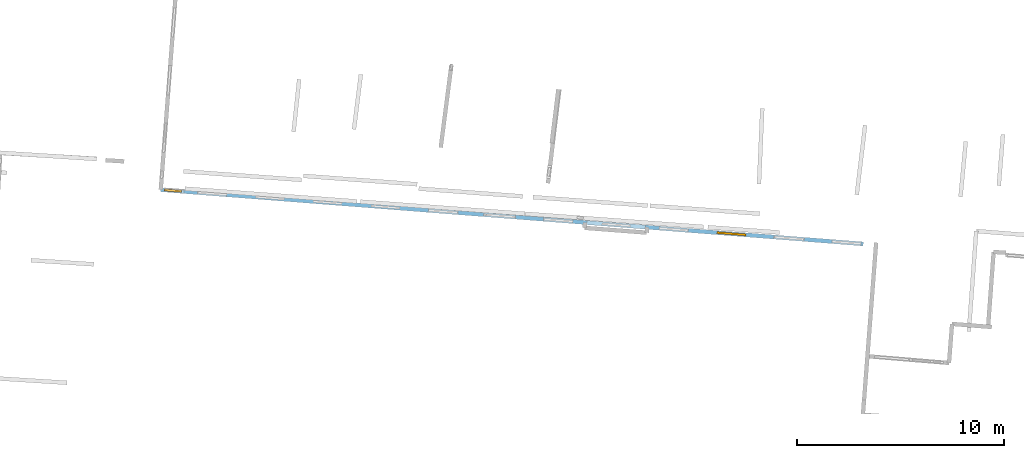
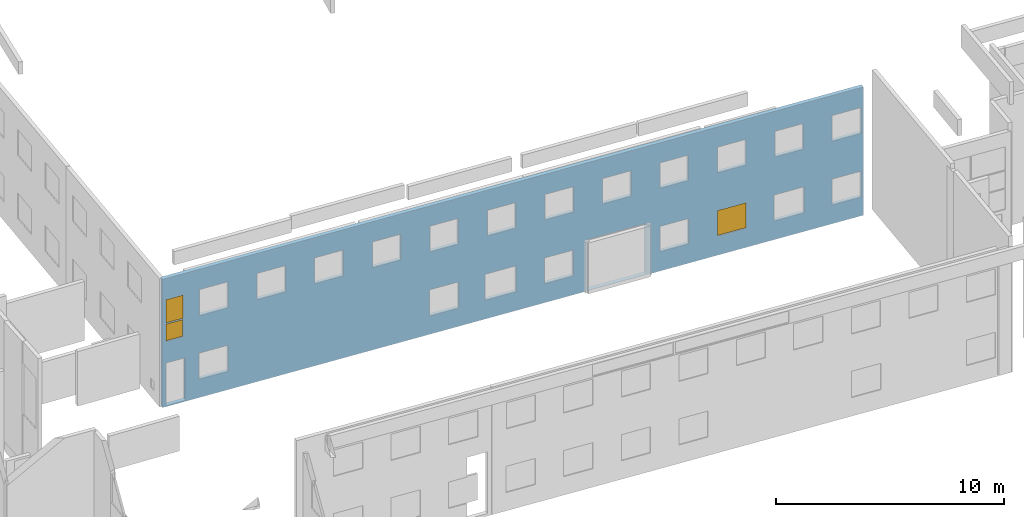
# One storey, part 13 of 27: 3 windows, 24 openings, plus 1 element that does not belong to this part.
"""IFC2X3 building model written with IfcOpenShell, lengths in metres."""

from ifc_helpers import new_model, entity, si_unit, converted_unit, derived_unit, direction, frame, frame_2d, origin, origin_2d_with_axis, place, context, subcontext, project, spatial, polyline, rectangle, outline, extrude, source, transform, mapped, material, layer, layer_set, layer_usage, type_object, type_shapes, element, fill, save


model = new_model("IFC2X3")

# Units and contexts
model_context = context("Model", 3, precision=1e-05, world=origin(), true_north=direction((0.0, 1.0)))
body_context = subcontext(model_context, "Body", "Model", "MODEL_VIEW")
ifc_project = project(units=[si_unit("LENGTHUNIT", "METRE"), si_unit("AREAUNIT", "SQUARE_METRE"), si_unit("VOLUMEUNIT", "CUBIC_METRE"), converted_unit("PLANEANGLEUNIT", "DEGREE", entity("IfcRatioMeasure", 0.0174532925199433), si_unit("PLANEANGLEUNIT", "RADIAN"), dimensions=[0, 0, 0, 0, 0, 0, 0]), si_unit("MASSUNIT", "GRAM", prefix="KILO"), derived_unit("MASSDENSITYUNIT", [(si_unit("MASSUNIT", "GRAM", prefix="KILO"), 1), (si_unit("LENGTHUNIT", "METRE"), -3)]), derived_unit("MOMENTOFINERTIAUNIT", [(si_unit("LENGTHUNIT", "METRE"), 4)]), si_unit("TIMEUNIT", "SECOND"), si_unit("FREQUENCYUNIT", "HERTZ"), si_unit("THERMODYNAMICTEMPERATUREUNIT", "DEGREE_CELSIUS"), derived_unit("THERMALTRANSMITTANCEUNIT", [(si_unit("MASSUNIT", "GRAM", prefix="KILO"), 1), (si_unit("THERMODYNAMICTEMPERATUREUNIT", "KELVIN"), -1), (si_unit("TIMEUNIT", "SECOND"), -3)]), derived_unit("VOLUMETRICFLOWRATEUNIT", [(si_unit("LENGTHUNIT", "METRE"), 3), (si_unit("TIMEUNIT", "SECOND"), -1)]), si_unit("ELECTRICCURRENTUNIT", "AMPERE"), si_unit("ELECTRICVOLTAGEUNIT", "VOLT"), si_unit("POWERUNIT", "WATT"), si_unit("FORCEUNIT", "NEWTON", prefix="KILO"), si_unit("ILLUMINANCEUNIT", "LUX"), si_unit("LUMINOUSFLUXUNIT", "LUMEN"), si_unit("LUMINOUSINTENSITYUNIT", "CANDELA"), derived_unit("USERDEFINED", [(si_unit("MASSUNIT", "GRAM", prefix="KILO"), -1), (si_unit("LENGTHUNIT", "METRE"), -2), (si_unit("TIMEUNIT", "SECOND"), 3), (si_unit("LUMINOUSFLUXUNIT", "LUMEN"), 1)]), derived_unit("LINEARVELOCITYUNIT", [(si_unit("LENGTHUNIT", "METRE"), 1), (si_unit("TIMEUNIT", "SECOND"), -1)]), si_unit("PRESSUREUNIT", "PASCAL"), derived_unit("USERDEFINED", [(si_unit("LENGTHUNIT", "METRE"), -2), (si_unit("MASSUNIT", "GRAM", prefix="KILO"), 1), (si_unit("TIMEUNIT", "SECOND"), -2)]), derived_unit("LINEARFORCEUNIT", [(si_unit("MASSUNIT", "GRAM", prefix="KILO"), 1), (si_unit("LENGTHUNIT", "METRE"), 1), (si_unit("TIMEUNIT", "SECOND"), -2), (si_unit("LENGTHUNIT", "METRE"), -1)]), derived_unit("PLANARFORCEUNIT", [(si_unit("MASSUNIT", "GRAM", prefix="KILO"), 1), (si_unit("LENGTHUNIT", "METRE"), 1), (si_unit("TIMEUNIT", "SECOND"), -2), (si_unit("LENGTHUNIT", "METRE"), -2)])], contexts=[model_context])

# Site, building, storey
placement_1 = place(None, origin())
site = spatial("IfcSite", under=ifc_project, at=placement_1, CompositionType="ELEMENT")
building = spatial("IfcBuilding", under=site, at=placement_1, CompositionType="ELEMENT")
storey_placement = place(placement_1, frame((0.0, 0.0, -61.043098449707)))
storey = spatial("IfcBuildingStorey", under=building, at=storey_placement, Name="level_-61.043098", CompositionType="ELEMENT", Elevation=-61.043098449707)

# Wall, openings, windows
ifc_material_1 = material(Name="Default wall")
ifc_layer = layer(ifc_material_1, 0.2)
ifc_layer_set = layer_set([ifc_layer], Name="wall_thickness_0.2000")
ifc_layer_usage = layer_usage(ifc_layer_set, "AXIS2", "POSITIVE", -0.1)
wall_type = type_object("IfcWallType", Name="wall_thickness_0.2000", PredefinedType="STANDARD", material=ifc_layer_set)
placement_2 = place(placement_1, frame((0.0, 0.0, -61.0783157348633)))
wall_placement = place(placement_2, frame((-70.5410936106186, 0.364161913204613, 0.0), z_axis=(0.0, 0.0, 1.0), x_axis=(0.997031285356377, -0.0769975065869715, 0.0)))
wall = element("IfcWallStandardCase", 1, at=wall_placement, inside=storey, type_object=wall_type, material=ifc_layer_usage, Name="Wall:863", ObjectType="Wall", context=body_context, shape_type="SweptSolid", body=[
    extrude(outline(polyline([(34.091740570846, -0.1), (34.091740570846, 0.1), (0.0, 0.1), (0.0, -0.1), (34.091740570846, -0.1)])), origin(), (0.0, 0.0, 1.0), 6.869140625),
])
opening_1_placement = place(wall_placement, frame((0.175669529657693, -0.1, 0.0593376159667969)))
element("IfcOpeningElement", 2, at=opening_1_placement, cuts=wall, Name="Opening : 950 x 2285 : 80", ObjectType="Opening", context=body_context, shape_type="SweptSolid", body=[
    extrude(rectangle(XDim=0.95, YDim=2.285, at=frame_2d((1.1425, 0.475), x_axis=(0.0, 1.0))), frame((0.0, 0.0, 0.0), z_axis=(0.0, 1.0, 0.0), x_axis=(0.0, 0.0, 1.0)), (0.0, 0.0, 1.0), 0.2),
])
opening_2_placement = place(wall_placement, frame((20.6733996380134, -0.1, 0.0425682067871094)))
element("IfcOpeningElement", 3, at=opening_2_placement, cuts=wall, Name="Opening : 2840 x 2715 : 81", ObjectType="Opening", context=body_context, shape_type="SweptSolid", body=[
    extrude(rectangle(XDim=2.84, YDim=2.715, at=frame_2d((1.3575, 1.42), x_axis=(0.0, 1.0))), frame((0.0, 0.0, 0.0), z_axis=(0.0, 1.0, 0.0), x_axis=(0.0, 0.0, 1.0)), (0.0, 0.0, 1.0), 0.2),
])
opening_3_placement = place(wall_placement, frame((21.4018079516808, -0.1, 4.43256759643555)))
element("IfcOpeningElement", 4, at=opening_3_placement, cuts=wall, Name="Opening : 1400 x 1370 : 82", ObjectType="Opening", context=body_context, shape_type="SweptSolid", body=[
    extrude(rectangle(XDim=1.4, YDim=1.37, at=frame_2d((0.685, 0.7), x_axis=(0.0, 1.0))), frame((0.0, 0.0, 0.0), z_axis=(0.0, 1.0, 0.0), x_axis=(0.0, 0.0, 1.0)), (0.0, 0.0, 1.0), 0.2),
])
opening_4_placement = place(wall_placement, frame((18.6005650597193, -0.1, 4.42756652832031)))
element("IfcOpeningElement", 5, at=opening_4_placement, cuts=wall, Name="Opening : 1405 x 1370 : 83", ObjectType="Opening", context=body_context, shape_type="SweptSolid", body=[
    extrude(rectangle(XDim=1.405, YDim=1.37, at=frame_2d((0.685, 0.7025), x_axis=(0.0, 1.0))), frame((0.0, 0.0, 0.0), z_axis=(0.0, 1.0, 0.0), x_axis=(0.0, 0.0, 1.0)), (0.0, 0.0, 1.0), 0.2),
])
opening_5_placement = place(wall_placement, frame((4.59927100477917, -0.1, 4.38933563232422)))
element("IfcOpeningElement", 6, at=opening_5_placement, cuts=wall, Name="Opening : 1410 x 1415 : 84", ObjectType="Opening", context=body_context, shape_type="SweptSolid", body=[
    extrude(rectangle(XDim=1.41, YDim=1.415, at=frame_2d((0.7075, 0.705), x_axis=(0.0, 1.0))), frame((0.0, 0.0, 0.0), z_axis=(0.0, 1.0, 0.0), x_axis=(0.0, 0.0, 1.0)), (0.0, 0.0, 1.0), 0.2),
])
opening_6_placement = place(wall_placement, frame((1.79896544522815, -0.1, 4.37933731079102)))
element("IfcOpeningElement", 7, at=opening_6_placement, cuts=wall, Name="Opening : 1405 x 1405 : 85", ObjectType="Opening", context=body_context, shape_type="SweptSolid", body=[
    extrude(rectangle(XDim=1.405, YDim=1.405, at=frame_2d((0.7025, 0.7025), x_axis=(0.0, 1.0))), frame((0.0, 0.0, 0.0), z_axis=(0.0, 1.0, 0.0), x_axis=(0.0, 0.0, 1.0)), (0.0, 0.0, 1.0), 0.2),
])
opening_7_placement = place(wall_placement, frame((7.40003180112796, -0.1, 4.39433670043945)))
element("IfcOpeningElement", 8, at=opening_7_placement, cuts=wall, Name="Opening : 1405 x 1395 : 86", ObjectType="Opening", context=body_context, shape_type="SweptSolid", body=[
    extrude(rectangle(XDim=1.405, YDim=1.395, at=frame_2d((0.6975, 0.7025), x_axis=(0.0, 1.0))), frame((0.0, 0.0, 0.0), z_axis=(0.0, 1.0, 0.0), x_axis=(0.0, 0.0, 1.0)), (0.0, 0.0, 1.0), 0.2),
])
opening_8_placement = place(wall_placement, frame((1.78067692275089, -0.1, 0.979335784912109)))
element("IfcOpeningElement", 9, at=opening_8_placement, cuts=wall, Name="Opening : 1420 x 1405 : 87", ObjectType="Opening", context=body_context, shape_type="SweptSolid", body=[
    extrude(rectangle(XDim=1.42, YDim=1.405, at=frame_2d((0.7025, 0.71), x_axis=(0.0, 1.0))), frame((0.0, 0.0, 0.0), z_axis=(0.0, 1.0, 0.0), x_axis=(0.0, 0.0, 1.0)), (0.0, 0.0, 1.0), 0.2),
])
opening_9_placement = place(wall_placement, frame((24.1869546370559, -0.1, 4.42756652832031)))
element("IfcOpeningElement", 10, at=opening_9_placement, cuts=wall, Name="Opening : 1400 x 1370 : 88", ObjectType="Opening", context=body_context, shape_type="SweptSolid", body=[
    extrude(rectangle(XDim=1.4, YDim=1.37, at=frame_2d((0.685, 0.7), x_axis=(0.0, 1.0))), frame((0.0, 0.0, 0.0), z_axis=(0.0, 1.0, 0.0), x_axis=(0.0, 0.0, 1.0)), (0.0, 0.0, 1.0), 0.2),
])
opening_10_placement = place(wall_placement, frame((29.7875311747154, -0.1, 4.41256713867188)))
element("IfcOpeningElement", 11, at=opening_10_placement, cuts=wall, Name="Opening : 1400 x 1385 : 89", ObjectType="Opening", context=body_context, shape_type="SweptSolid", body=[
    extrude(rectangle(XDim=1.4, YDim=1.385, at=frame_2d((0.6925, 0.7), x_axis=(0.0, 1.0))), frame((0.0, 0.0, 0.0), z_axis=(0.0, 1.0, 0.0), x_axis=(0.0, 0.0, 1.0)), (0.0, 0.0, 1.0), 0.2),
])
opening_11_placement = place(wall_placement, frame((32.5684003285411, -0.1, 4.41256713867188)))
element("IfcOpeningElement", 12, at=opening_11_placement, cuts=wall, Name="Opening : 1420 x 1390 : 90", ObjectType="Opening", context=body_context, shape_type="SweptSolid", body=[
    extrude(rectangle(XDim=1.42, YDim=1.39, at=frame_2d((0.695, 0.71), x_axis=(0.0, 1.0))), frame((0.0, 0.0, 0.0), z_axis=(0.0, 1.0, 0.0), x_axis=(0.0, 0.0, 1.0)), (0.0, 0.0, 1.0), 0.2),
])
opening_12_placement = place(wall_placement, frame((10.2015042481688, -0.1, 4.40756607055664)))
element("IfcOpeningElement", 13, at=opening_12_placement, cuts=wall, Name="Opening : 1405 x 1385 : 91", ObjectType="Opening", context=body_context, shape_type="SweptSolid", body=[
    extrude(rectangle(XDim=1.405, YDim=1.385, at=frame_2d((0.6925, 0.7025), x_axis=(0.0, 1.0))), frame((0.0, 0.0, 0.0), z_axis=(0.0, 1.0, 0.0), x_axis=(0.0, 0.0, 1.0)), (0.0, 0.0, 1.0), 0.2),
])
opening_13_placement = place(wall_placement, frame((12.9975627777284, -0.1, 4.40756607055664)))
element("IfcOpeningElement", 14, at=opening_13_placement, cuts=wall, Name="Opening : 1405 x 1385 : 92", ObjectType="Opening", context=body_context, shape_type="SweptSolid", body=[
    extrude(rectangle(XDim=1.405, YDim=1.385, at=frame_2d((0.6925, 0.7025), x_axis=(0.0, 1.0))), frame((0.0, 0.0, 0.0), z_axis=(0.0, 1.0, 0.0), x_axis=(0.0, 0.0, 1.0)), (0.0, 0.0, 1.0), 0.2),
])
opening_14_placement = place(wall_placement, frame((15.7978721303258, -0.1, 4.41756820678711)))
element("IfcOpeningElement", 15, at=opening_14_placement, cuts=wall, Name="Opening : 1405 x 1375 : 93", ObjectType="Opening", context=body_context, shape_type="SweptSolid", body=[
    extrude(rectangle(XDim=1.405, YDim=1.375, at=frame_2d((0.6875, 0.7025), x_axis=(0.0, 1.0))), frame((0.0, 0.0, 0.0), z_axis=(0.0, 1.0, 0.0), x_axis=(0.0, 0.0, 1.0)), (0.0, 0.0, 1.0), 0.2),
])
opening_15_placement = place(wall_placement, frame((26.9919317277781, -0.1, 4.41256713867188)))
element("IfcOpeningElement", 16, at=opening_15_placement, cuts=wall, Name="Opening : 1400 x 1380 : 94", ObjectType="Opening", context=body_context, shape_type="SweptSolid", body=[
    extrude(rectangle(XDim=1.4, YDim=1.38, at=frame_2d((0.69, 0.7), x_axis=(0.0, 1.0))), frame((0.0, 0.0, 0.0), z_axis=(0.0, 1.0, 0.0), x_axis=(0.0, 0.0, 1.0)), (0.0, 0.0, 1.0), 0.2),
])
opening_16_placement = place(wall_placement, frame((15.6733990489944, -0.1, 1.00256729125977)))
element("IfcOpeningElement", 17, at=opening_16_placement, cuts=wall, Name="Opening : 1535 x 1400 : 95", ObjectType="Opening", context=body_context, shape_type="SweptSolid", body=[
    extrude(rectangle(XDim=1.535, YDim=1.4, at=frame_2d((0.7, 0.7675), x_axis=(0.0, 1.0))), frame((0.0, 0.0, 0.0), z_axis=(0.0, 1.0, 0.0), x_axis=(0.0, 0.0, 1.0)), (0.0, 0.0, 1.0), 0.2),
])
opening_17_placement = place(wall_placement, frame((18.5683994261943, -0.1, 1.01256561279297)))
element("IfcOpeningElement", 18, at=opening_17_placement, cuts=wall, Name="Opening : 1425 x 1390 : 96", ObjectType="Opening", context=body_context, shape_type="SweptSolid", body=[
    extrude(rectangle(XDim=1.425, YDim=1.39, at=frame_2d((0.695, 0.7125), x_axis=(0.0, 1.0))), frame((0.0, 0.0, 0.0), z_axis=(0.0, 1.0, 0.0), x_axis=(0.0, 0.0, 1.0)), (0.0, 0.0, 1.0), 0.2),
])
opening_18_placement = place(wall_placement, frame((24.1934015219894, -0.1, 1.03256607055664)))
element("IfcOpeningElement", 19, at=opening_18_placement, cuts=wall, Name="Opening : 1405 x 1365 : 97", ObjectType="Opening", context=body_context, shape_type="SweptSolid", body=[
    extrude(rectangle(XDim=1.405, YDim=1.365, at=frame_2d((0.6825, 0.7025), x_axis=(0.0, 1.0))), frame((0.0, 0.0, 0.0), z_axis=(0.0, 1.0, 0.0), x_axis=(0.0, 0.0, 1.0)), (0.0, 0.0, 1.0), 0.2),
])
opening_19_placement = place(wall_placement, frame((29.7484020893475, -0.1, 0.992565155029297)))
element("IfcOpeningElement", 20, at=opening_19_placement, cuts=wall, Name="Opening : 1480 x 1405 : 98", ObjectType="Opening", context=body_context, shape_type="SweptSolid", body=[
    extrude(rectangle(XDim=1.48, YDim=1.405, at=frame_2d((0.7025, 0.74), x_axis=(0.0, 1.0))), frame((0.0, 0.0, 0.0), z_axis=(0.0, 1.0, 0.0), x_axis=(0.0, 0.0, 1.0)), (0.0, 0.0, 1.0), 0.2),
])
opening_20_placement = place(wall_placement, frame((32.5734009472892, -0.1, 1.00256729125977)))
element("IfcOpeningElement", 21, at=opening_20_placement, cuts=wall, Name="Opening : 1415 x 1395 : 99", ObjectType="Opening", context=body_context, shape_type="SweptSolid", body=[
    extrude(rectangle(XDim=1.415, YDim=1.395, at=frame_2d((0.6975, 0.7075), x_axis=(0.0, 1.0))), frame((0.0, 0.0, 0.0), z_axis=(0.0, 1.0, 0.0), x_axis=(0.0, 0.0, 1.0)), (0.0, 0.0, 1.0), 0.2),
])
opening_21_placement = place(wall_placement, frame((12.9833987386074, -0.1, 0.972564697265625)))
element("IfcOpeningElement", 22, at=opening_21_placement, cuts=wall, Name="Opening : 1435 x 1415 : 100", ObjectType="Opening", context=body_context, shape_type="SweptSolid", body=[
    extrude(rectangle(XDim=1.435, YDim=1.415, at=frame_2d((0.7075, 0.7175), x_axis=(0.0, 1.0))), frame((0.0, 0.0, 0.0), z_axis=(0.0, 1.0, 0.0), x_axis=(0.0, 0.0, 1.0)), (0.0, 0.0, 1.0), 0.2),
])
opening_22_placement = place(wall_placement, frame((26.9833996317755, -0.1, 1.02256774902344)))
opening_22 = element("IfcOpeningElement", 23, at=opening_22_placement, cuts=wall, Name="Opening : 1410 x 1370 : 101", ObjectType="Opening", context=body_context, shape_type="SweptSolid", body=[
    extrude(rectangle(XDim=1.41, YDim=1.37, at=frame_2d((0.685, 0.705), x_axis=(0.0, 1.0))), frame((0.0, 0.0, 0.0), z_axis=(0.0, 1.0, 0.0), x_axis=(0.0, 0.0, 1.0)), (0.0, 0.0, 1.0), 0.2),
])
opening_23_placement = place(wall_placement, frame((0.17339684269828, -0.1, 4.45256805419922)))
opening_23 = element("IfcOpeningElement", 24, at=opening_23_placement, cuts=wall, Name="Opening : 835 x 1275 : 102", ObjectType="Opening", context=body_context, shape_type="SweptSolid", body=[
    extrude(rectangle(XDim=0.835, YDim=1.275, at=frame_2d((0.6375, 0.4175), x_axis=(0.0, 1.0))), frame((0.0, 0.0, 0.0), z_axis=(0.0, 1.0, 0.0), x_axis=(0.0, 0.0, 1.0)), (0.0, 0.0, 1.0), 0.2),
])
opening_24_placement = place(wall_placement, frame((0.17339684269828, -0.1, 3.4925651550293)))
opening_24 = element("IfcOpeningElement", 25, at=opening_24_placement, cuts=wall, Name="Opening : 830 x 930 : 103", ObjectType="Opening", context=body_context, shape_type="SweptSolid", body=[
    extrude(rectangle(XDim=0.83, YDim=0.93, at=frame_2d((0.465, 0.415), x_axis=(0.0, 1.0))), frame((0.0, 0.0, 0.0), z_axis=(0.0, 1.0, 0.0), x_axis=(0.0, 0.0, 1.0)), (0.0, 0.0, 1.0), 0.2),
])
ifc_material_2 = material(Name="Window Default")
window_style_1 = type_object("IfcWindowStyle", Name="Window : 1410 x 1370mm", ConstructionType="NOTDEFINED", OperationType="NOTDEFINED", ParameterTakesPrecedence=False, Sizeable=False, material=ifc_material_2)
shared_shape_1 = source(origin(), body_context, "Body", "SweptSolid", [
    extrude(rectangle(XDim=0.1, YDim=1.41, at=origin_2d_with_axis()), frame((0.705, 0.1, 0.0), z_axis=(0.0, 0.0, 1.0), x_axis=(0.0, 1.0, 0.0)), (0.0, 0.0, 1.0), 1.37),
])
type_shapes(window_style_1, [shared_shape_1])
window_1_placement = place(opening_22_placement, origin())
window_1 = element("IfcWindow", 26, at=window_1_placement, inside=storey, type_object=window_style_1, Name="Window : 1410 x 1370mm : 90", ObjectType="Window : 1410 x 1370mm", OverallHeight=1.37, OverallWidth=1.41, context=body_context, shape_type="MappedRepresentation", body=[
    mapped(shared_shape_1, transform((0.0, 0.0, 0.0), scale=1.0)),
])
fill(opening_22, window_1)
window_style_2 = type_object("IfcWindowStyle", Name="Window : 835 x 1275mm", ConstructionType="NOTDEFINED", OperationType="NOTDEFINED", ParameterTakesPrecedence=False, Sizeable=False, material=ifc_material_2)
shared_shape_2 = source(origin(), body_context, "Body", "SweptSolid", [
    extrude(rectangle(XDim=0.1, YDim=0.835, at=origin_2d_with_axis()), frame((0.4175, 0.1, 0.0), z_axis=(0.0, 0.0, 1.0), x_axis=(0.0, 1.0, 0.0)), (0.0, 0.0, 1.0), 1.275),
])
type_shapes(window_style_2, [shared_shape_2])
window_2_placement = place(opening_23_placement, origin())
window_2 = element("IfcWindow", 27, at=window_2_placement, inside=storey, type_object=window_style_2, Name="Window : 835 x 1275mm : 91", ObjectType="Window : 835 x 1275mm", OverallHeight=1.275, OverallWidth=0.835, context=body_context, shape_type="MappedRepresentation", body=[
    mapped(shared_shape_2, transform((0.0, 0.0, 0.0), scale=1.0)),
])
fill(opening_23, window_2)
window_style_3 = type_object("IfcWindowStyle", Name="Window : 830 x 930mm", ConstructionType="NOTDEFINED", OperationType="NOTDEFINED", ParameterTakesPrecedence=False, Sizeable=False, material=ifc_material_2)
shared_shape_3 = source(origin(), body_context, "Body", "SweptSolid", [
    extrude(rectangle(XDim=0.1, YDim=0.83, at=origin_2d_with_axis()), frame((0.415, 0.1, 0.0), z_axis=(0.0, 0.0, 1.0), x_axis=(0.0, 1.0, 0.0)), (0.0, 0.0, 1.0), 0.93),
])
type_shapes(window_style_3, [shared_shape_3])
window_3_placement = place(opening_24_placement, origin())
window_3 = element("IfcWindow", 28, at=window_3_placement, inside=storey, type_object=window_style_3, Name="Window : 830 x 930mm : 92", ObjectType="Window : 830 x 930mm", OverallHeight=0.93, OverallWidth=0.83, context=body_context, shape_type="MappedRepresentation", body=[
    mapped(shared_shape_3, transform((0.0, 0.0, 0.0), scale=1.0)),
])
fill(opening_24, window_3)

save(model, "model.ifc")
